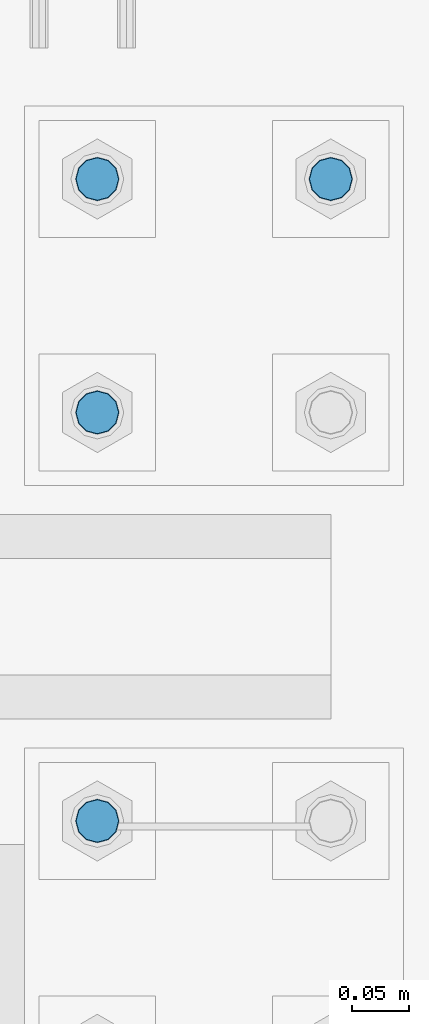
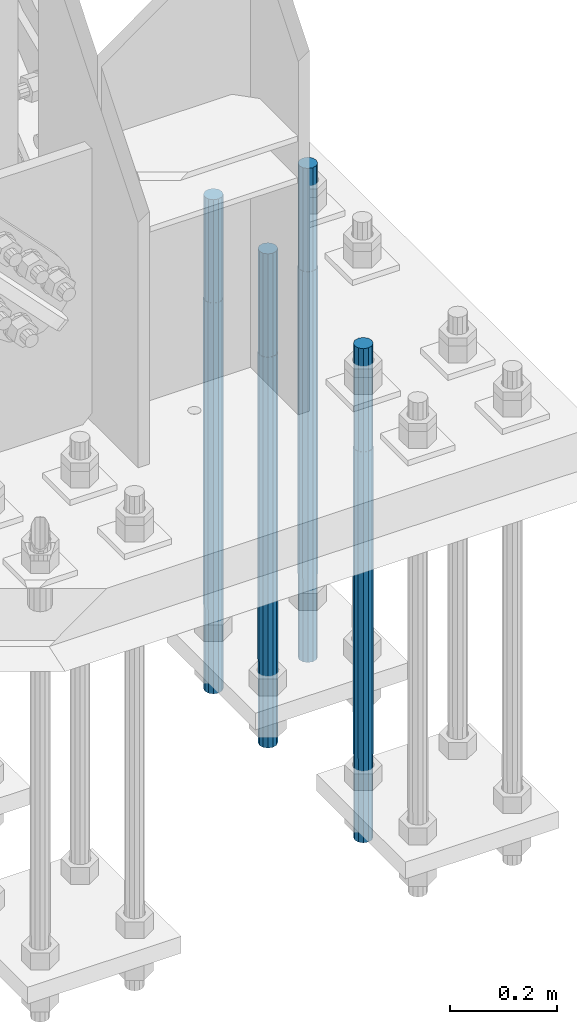
# One storey, part 1409 of 3843: 4 columns, 1 element without a shape of its own.
"""IFC2X3 building model written with IfcOpenShell, lengths in millimetres."""

from ifc_helpers import new_model, si_unit, frame, origin_with_axes, place, context, subcontext, project, spatial, faceted_brep, material, type_object, element, aggregate, save


model = new_model("IFC2X3")

# Units and contexts
model_context = context("Model", 3, precision=1e-05, world=origin_with_axes())
body_context = subcontext(model_context, "Body", "Model", "MODEL_VIEW")
ifc_project = project(units=[si_unit("LENGTHUNIT", "METRE", prefix="MILLI"), si_unit("AREAUNIT", "SQUARE_METRE"), si_unit("VOLUMEUNIT", "CUBIC_METRE"), si_unit("MASSUNIT", "GRAM", prefix="KILO"), si_unit("TIMEUNIT", "SECOND"), si_unit("PLANEANGLEUNIT", "RADIAN"), si_unit("SOLIDANGLEUNIT", "STERADIAN"), si_unit("THERMODYNAMICTEMPERATUREUNIT", "DEGREE_CELSIUS"), si_unit("LUMINOUSINTENSITYUNIT", "LUMEN")], contexts=[model_context])

# Site, building, storey
site_placement = place(None, origin_with_axes())
site = spatial("IfcSite", under=ifc_project, at=site_placement, CompositionType="ELEMENT")
building_placement = place(site_placement, origin_with_axes())
building = spatial("IfcBuilding", under=site, at=building_placement, Name="Undefined", CompositionType="ELEMENT")
storey_placement = place(building_placement, origin_with_axes())
storey = spatial("IfcBuildingStorey", under=building, at=storey_placement, Name="Undefined", CompositionType="ELEMENT", Elevation=0.0)

# Assembly, columns
assembly_placement = place(storey_placement, origin_with_axes())
assembly = element("IfcElementAssembly", 1, at=assembly_placement, inside=storey, Name="TEMPLATE", AssemblyPlace="NOTDEFINED", PredefinedType="RIGID_FRAME")
ifc_material = material(Name="Undefined/F1554-GR.55")
column_type = type_object("IfcColumnType", PredefinedType="NOTDEFINED")
column_1_placement = place(assembly_placement, frame((86156.8, 15379.7, 30022.8), z_axis=(-1.0, 0.0, 0.0), x_axis=(0.0, 0.0, -1.0)))
column_1 = element("IfcColumn", 2, at=column_1_placement, type_object=column_type, material=ifc_material, Name="ANCHOR_ROD", context=body_context, shape_type="Brep", body=[
    faceted_brep([(-234.950000000001, -16.0214699700155, 9.25), (-234.950000000001, -9.25, 16.0214699700155), (-234.950000000001, 0.0, 18.5), (-234.950000000001, 9.25, 16.0214699700155), (-234.950000000001, 16.0214699700155, 9.25), (-234.950000000001, 18.5, 0.0), (-234.950000000001, 16.0214699700155, -9.25), (-234.950000000001, 9.25, -16.0214699700155), (-234.950000000001, 0.0, -18.5), (-234.950000000001, -9.25, -16.0214699700155), (-234.950000000001, -16.0214699700155, -9.25), (-234.950000000001, -18.5, 0.0), (0.0, 18.5, 0.0), (0.0, 16.0214699700118, -9.25), (0.0, 9.25, -16.0214699700155), (0.0, 0.0, -18.5), (0.0, -9.25, -16.0214699700155), (0.0, -16.0214699700118, -9.25), (0.0, -18.5, 0.0), (0.0, -16.0214699700118, 9.25), (0.0, -9.25, 16.0214699700155), (0.0, 0.0, 18.5), (0.0, 9.25, 16.0214699700155), (0.0, 16.0214699700118, 9.25), (0.0, -16.4977839420972, 9.52500000000146), (0.0, -9.52500000000146, 16.4977839420972), (0.0, 0.0, 19.0499989999989), (0.0, 9.52500000000146, 16.4977839420972), (0.0, 16.4977839420972, 9.52500000000146), (0.0, 19.0500000000029, 0.0), (0.0, 16.4977839420972, -9.52500000000146), (0.0, 9.52500000000146, -16.4977839420972), (0.0, 0.0, -19.0499989999989), (0.0, -9.52500000000146, -16.4977839420972), (0.0, -16.4977839420972, -9.52500000000146), (0.0, -19.0500000000029, 0.0), (698.5, -19.0499999999993, 0.0), (698.5, -16.4977839420935, 9.52499999999418), (698.5, -9.52500000000146, 16.4977839420899), (698.5, 0.0, 19.0500000000029), (698.5, 9.52500000000146, 16.4977839420899), (698.5, 16.4977839420935, 9.52499999999418), (698.5, 19.0499999999993, 0.0), (698.5, 16.4977839420935, -9.52499999999418), (698.5, 9.52500000000146, -16.4977839420899), (698.5, 0.0, -19.0500000000029), (698.5, -9.52500000000146, -16.4977839420899), (698.5, -16.4977839420935, -9.52499999999418), (698.5, -9.25, 16.0214699700155), (698.5, 0.0, 18.5), (698.5, 9.25, 16.0214699700155), (698.5, 16.0214699700118, 9.25), (698.5, 18.5, 0.0), (698.5, 16.0214699700118, -9.25), (698.5, 9.25, -16.0214699700155), (698.5, 0.0, -18.5), (698.5, -9.25, -16.0214699700155), (698.5, -16.0214699700118, -9.25), (698.5, -18.5, 0.0), (698.5, -16.0214699700118, 9.25), (889.0, -9.25, -16.0214699700155), (889.0, 0.0, -18.5), (889.0, 9.25, -16.0214699700155), (889.0, 16.0214699700118, -9.25), (889.0, 18.5, 0.0), (889.0, 16.0214699700118, 9.25), (889.0, 9.25, 16.0214699700155), (889.0, 0.0, 18.5), (889.0, -9.25, 16.0214699700155), (889.0, -16.0214699700118, 9.25), (889.0, -18.5, 0.0), (889.0, -16.0214699700118, -9.25)], [[[0, 1, 2, 3, 4, 5, 6, 7, 8, 9, 10, 11]], [[6, 5, 12, 13]], [[7, 6, 13, 14]], [[8, 7, 14, 15]], [[9, 8, 15, 16]], [[10, 9, 16, 17]], [[11, 10, 17, 18]], [[0, 11, 18, 19]], [[1, 0, 19, 20]], [[2, 1, 20, 21]], [[3, 2, 21, 22]], [[4, 3, 22, 23]], [[5, 4, 23, 12]], [[24, 25, 26, 27, 28, 29, 30, 31, 32, 33, 34, 35], [22, 21, 20, 19, 18, 17, 16, 15, 14, 13, 12, 23]], [[24, 35, 36, 37]], [[25, 24, 37, 38]], [[26, 25, 38, 39]], [[27, 26, 39, 40]], [[28, 27, 40, 41]], [[29, 28, 41, 42]], [[30, 29, 42, 43]], [[31, 30, 43, 44]], [[32, 31, 44, 45]], [[33, 32, 45, 46]], [[34, 33, 46, 47]], [[35, 34, 47, 36]], [[46, 45, 44, 43, 42, 41, 40, 39, 38, 37, 36, 47], [48, 49, 50, 51, 52, 53, 54, 55, 56, 57, 58, 59]], [[60, 61, 62, 63, 64, 65, 66, 67, 68, 69, 70, 71]], [[68, 67, 49, 48]], [[69, 68, 48, 59]], [[70, 69, 59, 58]], [[71, 70, 58, 57]], [[60, 71, 57, 56]], [[61, 60, 56, 55]], [[62, 61, 55, 54]], [[63, 62, 54, 53]], [[64, 63, 53, 52]], [[65, 64, 52, 51]], [[66, 65, 51, 50]], [[67, 66, 50, 49]]]),
])
column_2_placement = place(assembly_placement, frame((85953.6, 14820.9, 30022.8), z_axis=(1.0, 0.0, 0.0), x_axis=(0.0, 0.0, -1.0)))
column_2 = element("IfcColumn", 3, at=column_2_placement, type_object=column_type, material=ifc_material, Name="ANCHOR_ROD", context=body_context, shape_type="Brep", body=[
    faceted_brep([(-234.950000000001, -16.0214699700155, 9.25), (-234.950000000001, -9.25, 16.0214699700155), (-234.950000000001, 0.0, 18.5), (-234.950000000001, 9.25, 16.0214699700155), (-234.950000000001, 16.0214699700155, 9.25), (-234.950000000001, 18.5, 0.0), (-234.950000000001, 16.0214699700155, -9.25), (-234.950000000001, 9.25, -16.0214699700155), (-234.950000000001, 0.0, -18.5), (-234.950000000001, -9.25, -16.0214699700155), (-234.950000000001, -16.0214699700155, -9.25), (-234.950000000001, -18.5, 0.0), (0.0, 18.5, 0.0), (0.0, 16.0214699700118, -9.25), (0.0, 9.25, -16.0214699700155), (0.0, 0.0, -18.5), (0.0, -9.25, -16.0214699700155), (0.0, -16.0214699700118, -9.25), (0.0, -18.5, 0.0), (0.0, -16.0214699700118, 9.25), (0.0, -9.25, 16.0214699700155), (0.0, 0.0, 18.5), (0.0, 9.25, 16.0214699700155), (0.0, 16.0214699700118, 9.25), (0.0, -16.4977839420972, 9.52500000000146), (0.0, -9.52500000000146, 16.4977839420972), (0.0, 0.0, 19.0499989999989), (0.0, 9.52500000000146, 16.4977839420972), (0.0, 16.4977839420972, 9.52500000000146), (0.0, 19.0500000000029, 0.0), (0.0, 16.4977839420972, -9.52500000000146), (0.0, 9.52500000000146, -16.4977839420972), (0.0, 0.0, -19.0499989999989), (0.0, -9.52500000000146, -16.4977839420972), (0.0, -16.4977839420972, -9.52500000000146), (0.0, -19.0500000000029, 0.0), (698.5, -19.0499999999993, 0.0), (698.5, -16.4977839420935, 9.52499999999418), (698.5, -9.52500000000146, 16.4977839420899), (698.5, 0.0, 19.0500000000029), (698.5, 9.52500000000146, 16.4977839420899), (698.5, 16.4977839420935, 9.52499999999418), (698.5, 19.0499999999993, 0.0), (698.5, 16.4977839420935, -9.52499999999418), (698.5, 9.52500000000146, -16.4977839420899), (698.5, 0.0, -19.0500000000029), (698.5, -9.52500000000146, -16.4977839420899), (698.5, -16.4977839420935, -9.52499999999418), (698.5, -9.25, 16.0214699700155), (698.5, 0.0, 18.5), (698.5, 9.25, 16.0214699700155), (698.5, 16.0214699700118, 9.25), (698.5, 18.5, 0.0), (698.5, 16.0214699700118, -9.25), (698.5, 9.25, -16.0214699700155), (698.5, 0.0, -18.5), (698.5, -9.25, -16.0214699700155), (698.5, -16.0214699700118, -9.25), (698.5, -18.5, 0.0), (698.5, -16.0214699700118, 9.25), (889.0, -9.25, -16.0214699700155), (889.0, 0.0, -18.5), (889.0, 9.25, -16.0214699700155), (889.0, 16.0214699700118, -9.25), (889.0, 18.5, 0.0), (889.0, 16.0214699700118, 9.25), (889.0, 9.25, 16.0214699700155), (889.0, 0.0, 18.5), (889.0, -9.25, 16.0214699700155), (889.0, -16.0214699700118, 9.25), (889.0, -18.5, 0.0), (889.0, -16.0214699700118, -9.25)], [[[0, 1, 2, 3, 4, 5, 6, 7, 8, 9, 10, 11]], [[6, 5, 12, 13]], [[7, 6, 13, 14]], [[8, 7, 14, 15]], [[9, 8, 15, 16]], [[10, 9, 16, 17]], [[11, 10, 17, 18]], [[0, 11, 18, 19]], [[1, 0, 19, 20]], [[2, 1, 20, 21]], [[3, 2, 21, 22]], [[4, 3, 22, 23]], [[5, 4, 23, 12]], [[24, 25, 26, 27, 28, 29, 30, 31, 32, 33, 34, 35], [22, 21, 20, 19, 18, 17, 16, 15, 14, 13, 12, 23]], [[24, 35, 36, 37]], [[25, 24, 37, 38]], [[26, 25, 38, 39]], [[27, 26, 39, 40]], [[28, 27, 40, 41]], [[29, 28, 41, 42]], [[30, 29, 42, 43]], [[31, 30, 43, 44]], [[32, 31, 44, 45]], [[33, 32, 45, 46]], [[34, 33, 46, 47]], [[35, 34, 47, 36]], [[46, 45, 44, 43, 42, 41, 40, 39, 38, 37, 36, 47], [48, 49, 50, 51, 52, 53, 54, 55, 56, 57, 58, 59]], [[60, 61, 62, 63, 64, 65, 66, 67, 68, 69, 70, 71]], [[68, 67, 49, 48]], [[69, 68, 48, 59]], [[70, 69, 59, 58]], [[71, 70, 58, 57]], [[60, 71, 57, 56]], [[61, 60, 56, 55]], [[62, 61, 55, 54]], [[63, 62, 54, 53]], [[64, 63, 53, 52]], [[65, 64, 52, 51]], [[66, 65, 51, 50]], [[67, 66, 50, 49]]]),
])
column_3_placement = place(assembly_placement, frame((85953.6, 15176.5, 30022.8), z_axis=(-1.0, 0.0, 0.0), x_axis=(0.0, 0.0, -1.0)))
column_3 = element("IfcColumn", 4, at=column_3_placement, type_object=column_type, material=ifc_material, Name="ANCHOR_ROD", context=body_context, shape_type="Brep", body=[
    faceted_brep([(-234.950000000001, -16.0214699700155, 9.25), (-234.950000000001, -9.25, 16.0214699700155), (-234.950000000001, 0.0, 18.5), (-234.950000000001, 9.25, 16.0214699700155), (-234.950000000001, 16.0214699700155, 9.25), (-234.950000000001, 18.5, 0.0), (-234.950000000001, 16.0214699700155, -9.25), (-234.950000000001, 9.25, -16.0214699700155), (-234.950000000001, 0.0, -18.5), (-234.950000000001, -9.25, -16.0214699700155), (-234.950000000001, -16.0214699700155, -9.25), (-234.950000000001, -18.5, 0.0), (0.0, 18.5, 0.0), (0.0, 16.0214699700118, -9.25), (0.0, 9.25, -16.0214699700155), (0.0, 0.0, -18.5), (0.0, -9.25, -16.0214699700155), (0.0, -16.0214699700118, -9.25), (0.0, -18.5, 0.0), (0.0, -16.0214699700118, 9.25), (0.0, -9.25, 16.0214699700155), (0.0, 0.0, 18.5), (0.0, 9.25, 16.0214699700155), (0.0, 16.0214699700118, 9.25), (0.0, -16.4977839420972, 9.52500000000146), (0.0, -9.52500000000146, 16.4977839420972), (0.0, 0.0, 19.0499989999989), (0.0, 9.52500000000146, 16.4977839420972), (0.0, 16.4977839420972, 9.52500000000146), (0.0, 19.0500000000029, 0.0), (0.0, 16.4977839420972, -9.52500000000146), (0.0, 9.52500000000146, -16.4977839420972), (0.0, 0.0, -19.0499989999989), (0.0, -9.52500000000146, -16.4977839420972), (0.0, -16.4977839420972, -9.52500000000146), (0.0, -19.0500000000029, 0.0), (698.5, -19.0499999999993, 0.0), (698.5, -16.4977839420935, 9.52499999999418), (698.5, -9.52500000000146, 16.4977839420899), (698.5, 0.0, 19.0500000000029), (698.5, 9.52500000000146, 16.4977839420899), (698.5, 16.4977839420935, 9.52499999999418), (698.5, 19.0499999999993, 0.0), (698.5, 16.4977839420935, -9.52499999999418), (698.5, 9.52500000000146, -16.4977839420899), (698.5, 0.0, -19.0500000000029), (698.5, -9.52500000000146, -16.4977839420899), (698.5, -16.4977839420935, -9.52499999999418), (698.5, -9.25, 16.0214699700155), (698.5, 0.0, 18.5), (698.5, 9.25, 16.0214699700155), (698.5, 16.0214699700118, 9.25), (698.5, 18.5, 0.0), (698.5, 16.0214699700118, -9.25), (698.5, 9.25, -16.0214699700155), (698.5, 0.0, -18.5), (698.5, -9.25, -16.0214699700155), (698.5, -16.0214699700118, -9.25), (698.5, -18.5, 0.0), (698.5, -16.0214699700118, 9.25), (889.0, -9.25, -16.0214699700155), (889.0, 0.0, -18.5), (889.0, 9.25, -16.0214699700155), (889.0, 16.0214699700118, -9.25), (889.0, 18.5, 0.0), (889.0, 16.0214699700118, 9.25), (889.0, 9.25, 16.0214699700155), (889.0, 0.0, 18.5), (889.0, -9.25, 16.0214699700155), (889.0, -16.0214699700118, 9.25), (889.0, -18.5, 0.0), (889.0, -16.0214699700118, -9.25)], [[[0, 1, 2, 3, 4, 5, 6, 7, 8, 9, 10, 11]], [[6, 5, 12, 13]], [[7, 6, 13, 14]], [[8, 7, 14, 15]], [[9, 8, 15, 16]], [[10, 9, 16, 17]], [[11, 10, 17, 18]], [[0, 11, 18, 19]], [[1, 0, 19, 20]], [[2, 1, 20, 21]], [[3, 2, 21, 22]], [[4, 3, 22, 23]], [[5, 4, 23, 12]], [[24, 25, 26, 27, 28, 29, 30, 31, 32, 33, 34, 35], [22, 21, 20, 19, 18, 17, 16, 15, 14, 13, 12, 23]], [[24, 35, 36, 37]], [[25, 24, 37, 38]], [[26, 25, 38, 39]], [[27, 26, 39, 40]], [[28, 27, 40, 41]], [[29, 28, 41, 42]], [[30, 29, 42, 43]], [[31, 30, 43, 44]], [[32, 31, 44, 45]], [[33, 32, 45, 46]], [[34, 33, 46, 47]], [[35, 34, 47, 36]], [[46, 45, 44, 43, 42, 41, 40, 39, 38, 37, 36, 47], [48, 49, 50, 51, 52, 53, 54, 55, 56, 57, 58, 59]], [[60, 61, 62, 63, 64, 65, 66, 67, 68, 69, 70, 71]], [[68, 67, 49, 48]], [[69, 68, 48, 59]], [[70, 69, 59, 58]], [[71, 70, 58, 57]], [[60, 71, 57, 56]], [[61, 60, 56, 55]], [[62, 61, 55, 54]], [[63, 62, 54, 53]], [[64, 63, 53, 52]], [[65, 64, 52, 51]], [[66, 65, 51, 50]], [[67, 66, 50, 49]]]),
])
column_4_placement = place(assembly_placement, frame((85953.6, 15379.7, 30022.8), z_axis=(-1.0, 0.0, 0.0), x_axis=(0.0, 0.0, -1.0)))
column_4 = element("IfcColumn", 5, at=column_4_placement, type_object=column_type, material=ifc_material, Name="ANCHOR_ROD", context=body_context, shape_type="Brep", body=[
    faceted_brep([(-234.950000000001, -16.0214699700155, 9.25), (-234.950000000001, -9.25, 16.0214699700155), (-234.950000000001, 0.0, 18.5), (-234.950000000001, 9.25, 16.0214699700155), (-234.950000000001, 16.0214699700155, 9.25), (-234.950000000001, 18.5, 0.0), (-234.950000000001, 16.0214699700155, -9.25), (-234.950000000001, 9.25, -16.0214699700155), (-234.950000000001, 0.0, -18.5), (-234.950000000001, -9.25, -16.0214699700155), (-234.950000000001, -16.0214699700155, -9.25), (-234.950000000001, -18.5, 0.0), (0.0, 18.5, 0.0), (0.0, 16.0214699700118, -9.25), (0.0, 9.25, -16.0214699700155), (0.0, 0.0, -18.5), (0.0, -9.25, -16.0214699700155), (0.0, -16.0214699700118, -9.25), (0.0, -18.5, 0.0), (0.0, -16.0214699700118, 9.25), (0.0, -9.25, 16.0214699700155), (0.0, 0.0, 18.5), (0.0, 9.25, 16.0214699700155), (0.0, 16.0214699700118, 9.25), (0.0, -16.4977839420972, 9.52500000000146), (0.0, -9.52500000000146, 16.4977839420972), (0.0, 0.0, 19.0499989999989), (0.0, 9.52500000000146, 16.4977839420972), (0.0, 16.4977839420972, 9.52500000000146), (0.0, 19.0500000000029, 0.0), (0.0, 16.4977839420972, -9.52500000000146), (0.0, 9.52500000000146, -16.4977839420972), (0.0, 0.0, -19.0499989999989), (0.0, -9.52500000000146, -16.4977839420972), (0.0, -16.4977839420972, -9.52500000000146), (0.0, -19.0500000000029, 0.0), (698.5, -19.0499999999993, 0.0), (698.5, -16.4977839420935, 9.52499999999418), (698.5, -9.52500000000146, 16.4977839420899), (698.5, 0.0, 19.0500000000029), (698.5, 9.52500000000146, 16.4977839420899), (698.5, 16.4977839420935, 9.52499999999418), (698.5, 19.0499999999993, 0.0), (698.5, 16.4977839420935, -9.52499999999418), (698.5, 9.52500000000146, -16.4977839420899), (698.5, 0.0, -19.0500000000029), (698.5, -9.52500000000146, -16.4977839420899), (698.5, -16.4977839420935, -9.52499999999418), (698.5, -9.25, 16.0214699700155), (698.5, 0.0, 18.5), (698.5, 9.25, 16.0214699700155), (698.5, 16.0214699700118, 9.25), (698.5, 18.5, 0.0), (698.5, 16.0214699700118, -9.25), (698.5, 9.25, -16.0214699700155), (698.5, 0.0, -18.5), (698.5, -9.25, -16.0214699700155), (698.5, -16.0214699700118, -9.25), (698.5, -18.5, 0.0), (698.5, -16.0214699700118, 9.25), (889.0, -9.25, -16.0214699700155), (889.0, 0.0, -18.5), (889.0, 9.25, -16.0214699700155), (889.0, 16.0214699700118, -9.25), (889.0, 18.5, 0.0), (889.0, 16.0214699700118, 9.25), (889.0, 9.25, 16.0214699700155), (889.0, 0.0, 18.5), (889.0, -9.25, 16.0214699700155), (889.0, -16.0214699700118, 9.25), (889.0, -18.5, 0.0), (889.0, -16.0214699700118, -9.25)], [[[0, 1, 2, 3, 4, 5, 6, 7, 8, 9, 10, 11]], [[6, 5, 12, 13]], [[7, 6, 13, 14]], [[8, 7, 14, 15]], [[9, 8, 15, 16]], [[10, 9, 16, 17]], [[11, 10, 17, 18]], [[0, 11, 18, 19]], [[1, 0, 19, 20]], [[2, 1, 20, 21]], [[3, 2, 21, 22]], [[4, 3, 22, 23]], [[5, 4, 23, 12]], [[24, 25, 26, 27, 28, 29, 30, 31, 32, 33, 34, 35], [22, 21, 20, 19, 18, 17, 16, 15, 14, 13, 12, 23]], [[24, 35, 36, 37]], [[25, 24, 37, 38]], [[26, 25, 38, 39]], [[27, 26, 39, 40]], [[28, 27, 40, 41]], [[29, 28, 41, 42]], [[30, 29, 42, 43]], [[31, 30, 43, 44]], [[32, 31, 44, 45]], [[33, 32, 45, 46]], [[34, 33, 46, 47]], [[35, 34, 47, 36]], [[46, 45, 44, 43, 42, 41, 40, 39, 38, 37, 36, 47], [48, 49, 50, 51, 52, 53, 54, 55, 56, 57, 58, 59]], [[60, 61, 62, 63, 64, 65, 66, 67, 68, 69, 70, 71]], [[68, 67, 49, 48]], [[69, 68, 48, 59]], [[70, 69, 59, 58]], [[71, 70, 58, 57]], [[60, 71, 57, 56]], [[61, 60, 56, 55]], [[62, 61, 55, 54]], [[63, 62, 54, 53]], [[64, 63, 53, 52]], [[65, 64, 52, 51]], [[66, 65, 51, 50]], [[67, 66, 50, 49]]]),
])
aggregate(assembly, [column_1, column_2, column_3, column_4])

save(model, "model.ifc")
